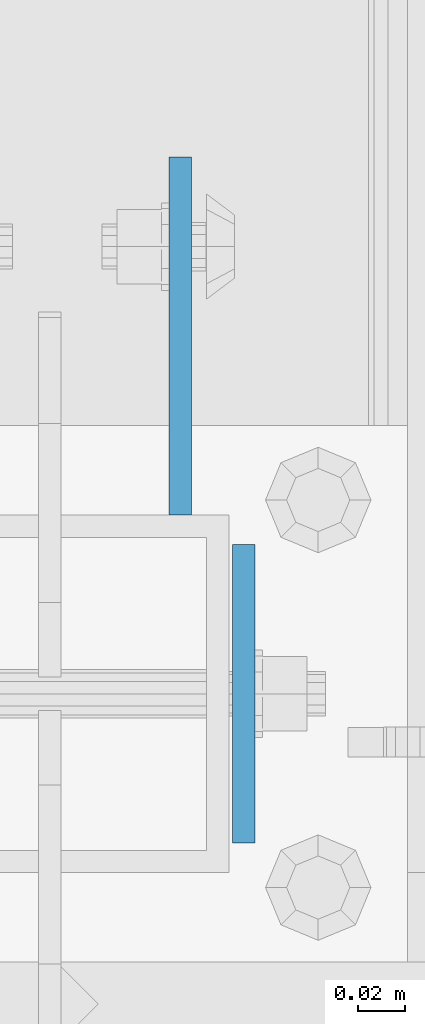
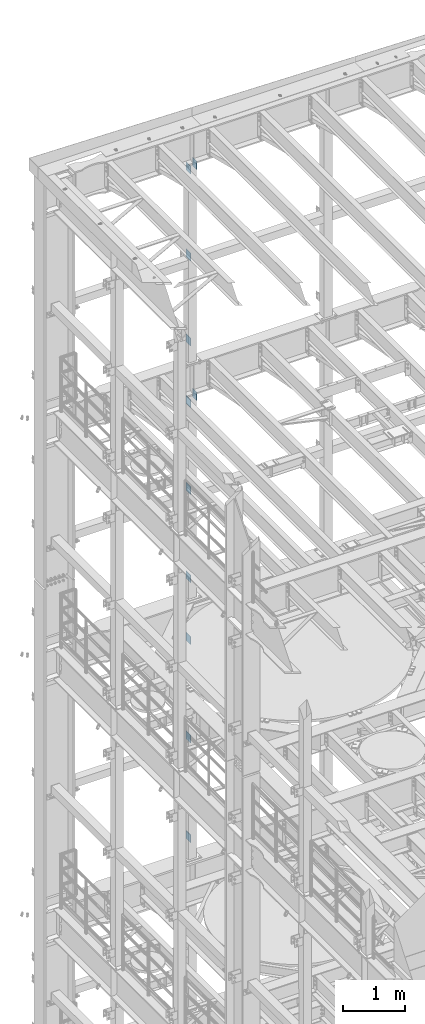
# One storey, part 1321 of 1876: 11 beams, 5 elements without a shape of their own.
"""IFC2X3 building model written with IfcOpenShell, lengths in millimetres."""

from ifc_helpers import new_model, si_unit, frame, origin_with_axes, place, context, subcontext, project, spatial, faceted_brep, material, type_object, element, aggregate, save


model = new_model("IFC2X3")

# Units and contexts
model_context = context("Model", 3, precision=1e-05, world=origin_with_axes())
body_context = subcontext(model_context, "Body", "Model", "MODEL_VIEW")
ifc_project = project(units=[si_unit("LENGTHUNIT", "METRE", prefix="MILLI"), si_unit("AREAUNIT", "SQUARE_METRE"), si_unit("VOLUMEUNIT", "CUBIC_METRE"), si_unit("MASSUNIT", "GRAM", prefix="KILO"), si_unit("TIMEUNIT", "SECOND"), si_unit("PLANEANGLEUNIT", "RADIAN"), si_unit("SOLIDANGLEUNIT", "STERADIAN"), si_unit("THERMODYNAMICTEMPERATUREUNIT", "DEGREE_CELSIUS"), si_unit("LUMINOUSINTENSITYUNIT", "LUMEN")], contexts=[model_context])

# Site, building, storey
site_placement = place(None, origin_with_axes())
site = spatial("IfcSite", under=ifc_project, at=site_placement, CompositionType="ELEMENT")
building_placement = place(site_placement, origin_with_axes())
building = spatial("IfcBuilding", under=site, at=building_placement, Name="Undefined", CompositionType="ELEMENT")
storey_placement = place(building_placement, origin_with_axes())
storey = spatial("IfcBuildingStorey", under=building, at=storey_placement, Name="Undefined", CompositionType="ELEMENT", Elevation=0.0)

# Assembly, beams
assembly_1_placement = place(storey_placement, origin_with_axes())
assembly_1 = element("IfcElementAssembly", 1, at=assembly_1_placement, inside=storey, Name="FRAME", AssemblyPlace="NOTDEFINED", PredefinedType="RIGID_FRAME")
ifc_material = material(Name="STEEL/A36")
beam_type_1 = type_object("IfcBeamType", PredefinedType="NOTDEFINED")
beam_1_placement = place(assembly_1_placement, frame((2595.5512944527, 13792.2, 21678.9), z_axis=(0.0, 0.0, -1.0), x_axis=(0.0, 1.0, 0.0)))
beam_1 = element("IfcBeam", 2, at=beam_1_placement, type_object=beam_type_1, material=ifc_material, Name="PLATE", context=body_context, shape_type="Brep", body=[
    faceted_brep([(0.0, 4.76249999999982, -76.1999999999998), (3.63797880709171e-12, 4.76249999999982, 76.1999969482422), (152.399993896484, 4.76250000000073, 76.1999969482422), (152.4, 4.76249999999982, -76.1999999999998), (3.63797880709171e-12, -4.76249999999982, 76.1999969482422), (152.399993896484, -4.76250000000073, 76.1999969482422), (0.0, -4.76249999999982, -76.1999999999998), (152.4, -4.76249999999982, -76.1999999999998)], [[[0, 1, 2, 3]], [[4, 5, 2, 1]], [[4, 6, 7, 5]], [[6, 0, 3, 7]], [[5, 7, 3, 2]], [[6, 4, 1, 0]]]),
])
beam_2_placement = place(assembly_1_placement, frame((2595.5512944527, 13792.2, 19958.05), z_axis=(0.0, 0.0, -1.0), x_axis=(0.0, 1.0, 0.0)))
beam_2 = element("IfcBeam", 3, at=beam_2_placement, type_object=beam_type_1, material=ifc_material, Name="PLATE", context=body_context, shape_type="Brep", body=[
    faceted_brep([(0.0, 4.76249999999982, -76.1999999999998), (3.63797880709171e-12, 4.76249999999982, 76.1999969482422), (152.399993896484, 4.76250000000073, 76.1999969482422), (152.4, 4.76249999999982, -76.1999999999998), (3.63797880709171e-12, -4.76249999999982, 76.1999969482422), (152.399993896484, -4.76250000000073, 76.1999969482422), (0.0, -4.76249999999982, -76.1999999999998), (152.4, -4.76249999999982, -76.1999999999998)], [[[0, 1, 2, 3]], [[4, 5, 2, 1]], [[4, 6, 7, 5]], [[6, 0, 3, 7]], [[5, 7, 3, 2]], [[6, 4, 1, 0]]]),
])
beam_3_placement = place(assembly_1_placement, frame((2595.5512944527, 13792.2, 18275.3), z_axis=(0.0, 0.0, -1.0), x_axis=(0.0, 1.0, 0.0)))
beam_3 = element("IfcBeam", 4, at=beam_3_placement, type_object=beam_type_1, material=ifc_material, Name="PLATE", context=body_context, shape_type="Brep", body=[
    faceted_brep([(0.0, 4.76249999999982, -76.1999999999998), (3.63797880709171e-12, 4.76249999999982, 76.1999969482422), (152.399993896484, 4.76250000000073, 76.1999969482422), (152.4, 4.76249999999982, -76.1999999999998), (3.63797880709171e-12, -4.76249999999982, 76.1999969482422), (152.399993896484, -4.76250000000073, 76.1999969482422), (0.0, -4.76249999999982, -76.1999999999998), (152.4, -4.76249999999982, -76.1999999999998)], [[[0, 1, 2, 3]], [[4, 5, 2, 1]], [[4, 6, 7, 5]], [[6, 0, 3, 7]], [[5, 7, 3, 2]], [[6, 4, 1, 0]]]),
])
aggregate(assembly_1, [beam_1, beam_2, beam_3])

assembly_2_placement = place(storey_placement, origin_with_axes())
assembly_2 = element("IfcElementAssembly", 5, at=assembly_2_placement, inside=storey, Name="FRAME", AssemblyPlace="NOTDEFINED", PredefinedType="RIGID_FRAME")
beam_4_placement = place(assembly_2_placement, frame((2595.5512944527, 13792.2, 17056.1), z_axis=(0.0, 0.0, -1.0), x_axis=(0.0, 1.0, 0.0)))
beam_4 = element("IfcBeam", 6, at=beam_4_placement, type_object=beam_type_1, material=ifc_material, Name="PLATE", context=body_context, shape_type="Brep", body=[
    faceted_brep([(0.0, 4.76249999999982, -76.1999999999998), (3.63797880709171e-12, 4.76249999999982, 76.1999969482422), (152.399993896484, 4.76250000000073, 76.1999969482422), (152.4, 4.76249999999982, -76.1999999999998), (3.63797880709171e-12, -4.76249999999982, 76.1999969482422), (152.399993896484, -4.76250000000073, 76.1999969482422), (0.0, -4.76249999999982, -76.1999999999998), (152.4, -4.76249999999982, -76.1999999999998)], [[[0, 1, 2, 3]], [[4, 5, 2, 1]], [[4, 6, 7, 5]], [[6, 0, 3, 7]], [[5, 7, 3, 2]], [[6, 4, 1, 0]]]),
])
beam_5_placement = place(assembly_2_placement, frame((2595.5512944527, 13792.2, 15335.25), z_axis=(0.0, 0.0, -1.0), x_axis=(0.0, 1.0, 0.0)))
beam_5 = element("IfcBeam", 7, at=beam_5_placement, type_object=beam_type_1, material=ifc_material, Name="PLATE", context=body_context, shape_type="Brep", body=[
    faceted_brep([(0.0, 4.76249999999982, -76.1999999999998), (3.63797880709171e-12, 4.76249999999982, 76.1999969482422), (152.399993896484, 4.76250000000073, 76.1999969482422), (152.4, 4.76249999999982, -76.1999999999998), (3.63797880709171e-12, -4.76249999999982, 76.1999969482422), (152.399993896484, -4.76250000000073, 76.1999969482422), (0.0, -4.76249999999982, -76.1999999999998), (152.4, -4.76249999999982, -76.1999999999998)], [[[0, 1, 2, 3]], [[4, 5, 2, 1]], [[4, 6, 7, 5]], [[6, 0, 3, 7]], [[5, 7, 3, 2]], [[6, 4, 1, 0]]]),
])
beam_6_placement = place(assembly_2_placement, frame((2595.5512944527, 13792.2, 13589.0), z_axis=(0.0, 0.0, -1.0), x_axis=(0.0, 1.0, 0.0)))
beam_6 = element("IfcBeam", 8, at=beam_6_placement, type_object=beam_type_1, material=ifc_material, Name="PLATE", context=body_context, shape_type="Brep", body=[
    faceted_brep([(0.0, 4.76249999999982, -76.1999999999998), (3.63797880709171e-12, 4.76249999999982, 76.1999969482422), (152.399993896484, 4.76250000000073, 76.1999969482422), (152.4, 4.76249999999982, -76.1999999999998), (3.63797880709171e-12, -4.76249999999982, 76.1999969482422), (152.399993896484, -4.76250000000073, 76.1999969482422), (0.0, -4.76249999999982, -76.1999999999998), (152.4, -4.76249999999982, -76.1999999999998)], [[[0, 1, 2, 3]], [[4, 5, 2, 1]], [[4, 6, 7, 5]], [[6, 0, 3, 7]], [[5, 7, 3, 2]], [[6, 4, 1, 0]]]),
])
aggregate(assembly_2, [beam_4, beam_5, beam_6])

assembly_3_placement = place(storey_placement, origin_with_axes())
assembly_3 = element("IfcElementAssembly", 9, at=assembly_3_placement, inside=storey, Name="FRAME", AssemblyPlace="NOTDEFINED", PredefinedType="RIGID_FRAME")
beam_7_placement = place(assembly_3_placement, frame((2595.5512944527, 13792.2, 12369.8), z_axis=(0.0, 0.0, -1.0), x_axis=(0.0, 1.0, 0.0)))
beam_7 = element("IfcBeam", 10, at=beam_7_placement, type_object=beam_type_1, material=ifc_material, Name="PLATE", context=body_context, shape_type="Brep", body=[
    faceted_brep([(0.0, 4.76249999999982, -76.1999999999998), (3.63797880709171e-12, 4.76249999999982, 76.1999969482422), (152.399993896484, 4.76250000000073, 76.1999969482422), (152.4, 4.76249999999982, -76.1999999999998), (3.63797880709171e-12, -4.76249999999982, 76.1999969482422), (152.399993896484, -4.76250000000073, 76.1999969482422), (0.0, -4.76249999999982, -76.1999999999998), (152.4, -4.76249999999982, -76.1999999999998)], [[[0, 1, 2, 3]], [[4, 5, 2, 1]], [[4, 6, 7, 5]], [[6, 0, 3, 7]], [[5, 7, 3, 2]], [[6, 4, 1, 0]]]),
])
beam_8_placement = place(assembly_3_placement, frame((2595.5512944527, 13792.2, 10420.35), z_axis=(0.0, 0.0, -1.0), x_axis=(0.0, 1.0, 0.0)))
beam_8 = element("IfcBeam", 11, at=beam_8_placement, type_object=beam_type_1, material=ifc_material, Name="PLATE", context=body_context, shape_type="Brep", body=[
    faceted_brep([(0.0, 4.76249999999982, -76.1999999999998), (3.63797880709171e-12, 4.76249999999982, 76.1999969482422), (152.399993896484, 4.76250000000073, 76.1999969482422), (152.4, 4.76249999999982, -76.1999999999998), (3.63797880709171e-12, -4.76249999999982, 76.1999969482422), (152.399993896484, -4.76250000000073, 76.1999969482422), (0.0, -4.76249999999982, -76.1999999999998), (152.4, -4.76249999999982, -76.1999999999998)], [[[0, 1, 2, 3]], [[4, 5, 2, 1]], [[4, 6, 7, 5]], [[6, 0, 3, 7]], [[5, 7, 3, 2]], [[6, 4, 1, 0]]]),
])
beam_9_placement = place(assembly_3_placement, frame((2595.5512944527, 13792.2, 8445.5), z_axis=(0.0, 0.0, -1.0), x_axis=(0.0, 1.0, 0.0)))
beam_9 = element("IfcBeam", 12, at=beam_9_placement, type_object=beam_type_1, material=ifc_material, Name="PLATE", context=body_context, shape_type="Brep", body=[
    faceted_brep([(0.0, 4.76249999999982, -76.1999999999998), (3.63797880709171e-12, 4.76249999999982, 76.1999969482422), (152.399993896484, 4.76250000000073, 76.1999969482422), (152.4, 4.76249999999982, -76.1999999999998), (3.63797880709171e-12, -4.76249999999982, 76.1999969482422), (152.399993896484, -4.76250000000073, 76.1999969482422), (0.0, -4.76249999999982, -76.1999999999998), (152.4, -4.76249999999982, -76.1999999999998)], [[[0, 1, 2, 3]], [[4, 5, 2, 1]], [[4, 6, 7, 5]], [[6, 0, 3, 7]], [[5, 7, 3, 2]], [[6, 4, 1, 0]]]),
])
aggregate(assembly_3, [beam_7, beam_8, beam_9])

# Assembly, beam
assembly_4_placement = place(storey_placement, origin_with_axes())
assembly_4 = element("IfcElementAssembly", 13, at=assembly_4_placement, inside=storey, Name="BEAM", AssemblyPlace="NOTDEFINED", PredefinedType="RIGID_FRAME")
beam_type_2 = type_object("IfcBeamType", PredefinedType="NOTDEFINED")
beam_10_placement = place(assembly_4_placement, frame((2622.55, 13779.5, 17278.35), z_axis=(0.0, 0.0, -1.0), x_axis=(0.0, -1.0, 0.0)))
beam_10 = element("IfcBeam", 14, at=beam_10_placement, type_object=beam_type_2, material=ifc_material, Name="PLATE", context=body_context, shape_type="Brep", body=[
    faceted_brep([(0.0, 4.76249999999982, -82.5499999999993), (0.0, 4.76249999999982, 82.5499999999993), (127.0, 4.76249999999982, 82.5499999999993), (127.0, 4.76249999999982, -82.5499999999993), (0.0, -4.76249999999982, 82.5499999999993), (127.0, -4.76249999999982, 82.5499999999993), (0.0, -4.76249999999982, -82.5499999999993), (127.0, -4.76249999999982, -82.5499999999993)], [[[0, 1, 2, 3]], [[1, 4, 5, 2]], [[4, 6, 7, 5]], [[6, 0, 3, 7]], [[5, 7, 3, 2]], [[6, 4, 1, 0]]]),
])
aggregate(assembly_4, [beam_10])

assembly_5_placement = place(storey_placement, origin_with_axes())
assembly_5 = element("IfcElementAssembly", 15, at=assembly_5_placement, inside=storey, Name="BEAM", AssemblyPlace="NOTDEFINED", PredefinedType="RIGID_FRAME")
beam_11_placement = place(assembly_5_placement, frame((2622.55, 13779.5, 21850.35), z_axis=(0.0, 0.0, -1.0), x_axis=(0.0, -1.0, 0.0)))
beam_11 = element("IfcBeam", 16, at=beam_11_placement, type_object=beam_type_2, material=ifc_material, Name="PLATE", context=body_context, shape_type="Brep", body=[
    faceted_brep([(0.0, 4.76249999999982, -82.5499999999993), (0.0, 4.76249999999982, 82.5499999999993), (127.0, 4.76249999999982, 82.5499999999993), (127.0, 4.76249999999982, -82.5499999999993), (0.0, -4.76249999999982, 82.5499999999993), (127.0, -4.76249999999982, 82.5499999999993), (0.0, -4.76249999999982, -82.5499999999993), (127.0, -4.76249999999982, -82.5499999999993)], [[[0, 1, 2, 3]], [[1, 4, 5, 2]], [[4, 6, 7, 5]], [[6, 0, 3, 7]], [[5, 7, 3, 2]], [[6, 4, 1, 0]]]),
])
aggregate(assembly_5, [beam_11])

save(model, "model.ifc")
